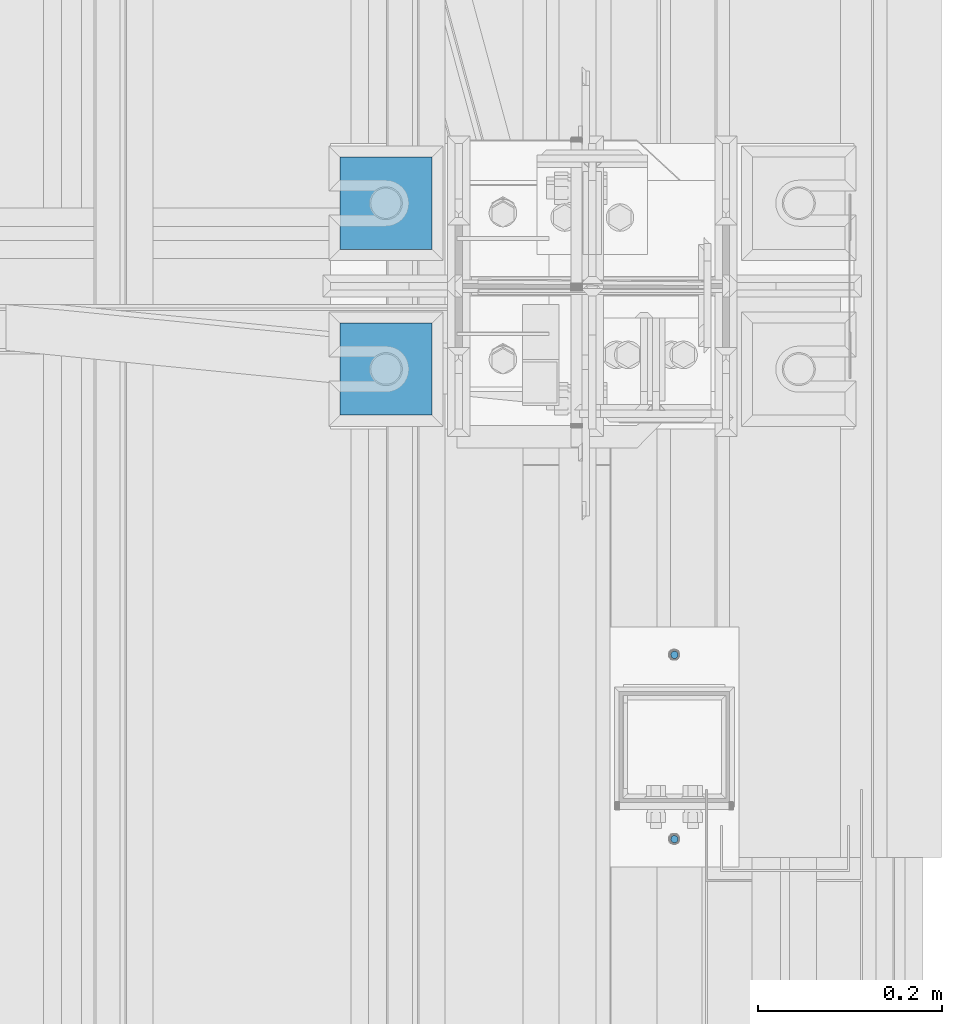
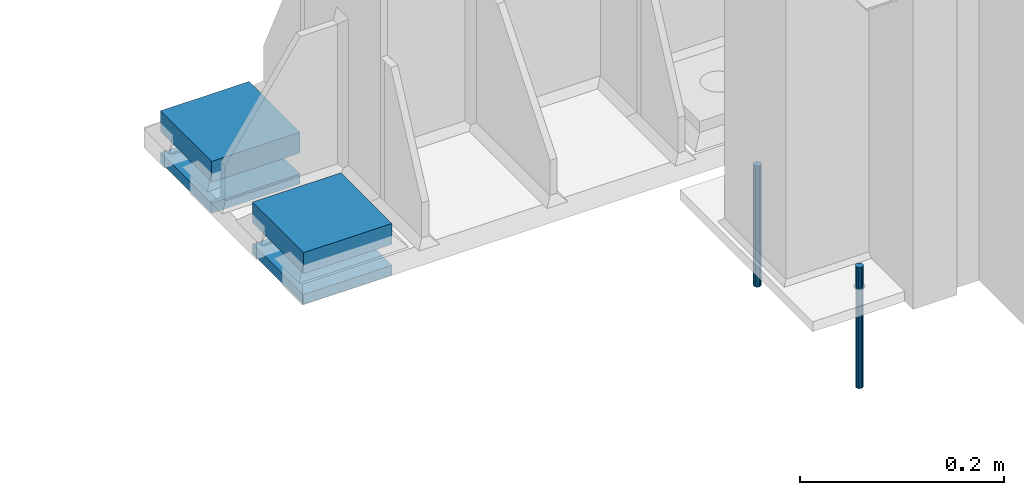
# One storey, part 101 of 709: 6 beams, 6 elements without a shape of their own.
"""IFC4 building model written with IfcOpenShell, lengths in millimetres."""

import ifcopenshell
import ifcopenshell.guid

model = None  # the IFC model being written
_history = None  # IfcOwnerHistory: only IFC2X3 demands one
_inside = {}  # id of a spatial element -> (the spatial element, [elements in it])
_under = {}  # id of a project, library or spatial element -> (it, [spatial elements below it])
_declared = {}  # id of a project -> (the project, [libraries it declares])
_typed = {}  # id of a type object -> (the type object, [elements of that type])
_made_of = {}  # id of a material, layer set ... -> (it, [elements and type objects made of it])


def new_model(schema):
    """Start an empty IFC model of exactly this schema.

    Asked for "IFC4X3", IfcOpenShell would pick the latest addendum, in which some entities
    have other attributes; the version numbers below select the first issue.
    IFC2X3 requires an IfcOwnerHistory on every rooted entity: one is made here for all.
    """
    global model, _history
    if schema == "IFC4X3":
        model = ifcopenshell.file(schema_version=(4, 3, 0, 0))
    else:
        model = ifcopenshell.file(schema=schema)
    _inside.clear()
    _under.clear()
    _declared.clear()
    _typed.clear()
    _made_of.clear()
    _history = None
    if model.schema == "IFC2X3":
        org = make("IfcOrganization", Name="unknown")
        user = make(
            "IfcPersonAndOrganization",
            ThePerson=make("IfcPerson", FamilyName="unknown"),
            TheOrganization=org,
        )
        app = make(
            "IfcApplication",
            ApplicationDeveloper=org,
            Version="unknown",
            ApplicationFullName="unknown",
            ApplicationIdentifier="unknown",
        )
        _history = make(
            "IfcOwnerHistory",
            OwningUser=user,
            OwningApplication=app,
            ChangeAction="ADDED",
            CreationDate=0,
        )
    return model


def make(cls, **values):
    """One entity of the class cls with the attributes given. An attribute that is None is left unset."""
    return model.create_entity(
        cls, **{name: value for name, value in values.items() if value is not None}
    )


def rooted(cls, **values):
    """An entity with a GlobalId (a new one), such as an element, a storey or a relation."""
    return make(cls, GlobalId=ifcopenshell.guid.new(), OwnerHistory=_history, **values)


def si_unit(unit_type, name, prefix=None):
    """IfcSIUnit, for example si_unit("LENGTHUNIT", "METRE", prefix="MILLI")."""
    return make("IfcSIUnit", UnitType=unit_type, Prefix=prefix, Name=name)


def assignment(units):
    """IfcUnitAssignment: the units of a project."""
    return None if units is None else make("IfcUnitAssignment", Units=units)


def point(xyz):
    """IfcCartesianPoint."""
    return None if xyz is None else make("IfcCartesianPoint", Coordinates=xyz)


def direction(xyz):
    """IfcDirection."""
    return None if xyz is None else make("IfcDirection", DirectionRatios=xyz)


def frame(location, z_axis=None, x_axis=None):
    """IfcAxis2Placement3D, a coordinate frame: its origin and axes. An axis left out is left unset."""
    return make(
        "IfcAxis2Placement3D",
        Location=point(location),
        Axis=direction(z_axis),
        RefDirection=direction(x_axis),
    )


def origin_with_axes():
    """The frame at (0, 0, 0) with the z axis (0, 0, 1) and the x axis (1, 0, 0) written out."""
    return frame((0.0, 0.0, 0.0), z_axis=(0.0, 0.0, 1.0), x_axis=(1.0, 0.0, 0.0))


def place(relative_to, where):
    """IfcLocalPlacement: puts the frame where relative to a parent placement (None: the world)."""
    return make(
        "IfcLocalPlacement", PlacementRelTo=relative_to, RelativePlacement=where
    )


def context(
    kind, dimensions, precision=None, world=None, true_north=None, identifier=None
):
    """IfcGeometricRepresentationContext, for example the 3D "Model" context."""
    return make(
        "IfcGeometricRepresentationContext",
        ContextIdentifier=identifier,
        ContextType=kind,
        CoordinateSpaceDimension=dimensions,
        Precision=precision,
        WorldCoordinateSystem=world,
        TrueNorth=true_north,
    )


def subcontext(parent, identifier, kind, view, scale=None):
    """IfcGeometricRepresentationSubContext, for example "Body" below "Model"."""
    return make(
        "IfcGeometricRepresentationSubContext",
        ContextIdentifier=identifier,
        ContextType=kind,
        ParentContext=parent,
        TargetScale=scale,
        TargetView=view,
    )


def project(units=None, contexts=None):
    """IfcProject with its units and contexts."""
    return rooted(
        "IfcProject",
        Name="project",
        RepresentationContexts=contexts,
        UnitsInContext=assignment(units),
    )


def spatial(cls, under=None, at=None, **own):
    """A site, building, storey or space (cls), placed at a placement, below another one or the project."""
    s = rooted(cls, ObjectPlacement=at, **own)
    if under is not None:
        _under.setdefault(under.id(), (under, []))[1].append(s)
    return s


def point_list(points):
    """IfcCartesianPointList2D or 3D."""
    cls = (
        "IfcCartesianPointList2D" if len(points[0]) == 2 else "IfcCartesianPointList3D"
    )
    return make(cls, CoordList=points)


def line(*indices):
    """IfcLineIndex: a straight run through numbered points of an indexed curve."""
    return model.create_entity("IfcLineIndex", indices)


def indexed_curve(points, segments=None, self_intersect=None):
    """IfcIndexedPolyCurve: lines and arcs through numbered points (the first is 1)."""
    return make(
        "IfcIndexedPolyCurve",
        Points=point_list(points),
        Segments=segments,
        SelfIntersect=self_intersect,
    )


def outline(outer, holes=None, kind="AREA"):
    """IfcArbitraryClosedProfileDef: a profile drawn as a closed curve; with holes, ...WithVoids."""
    if holes is None:
        return make("IfcArbitraryClosedProfileDef", ProfileType=kind, OuterCurve=outer)
    return make(
        "IfcArbitraryProfileDefWithVoids",
        ProfileType=kind,
        OuterCurve=outer,
        InnerCurves=holes,
    )


def extrude(swept, where, along, depth):
    """IfcExtrudedAreaSolid: the profile swept, set in the frame where, extruded along a direction by depth."""
    return make(
        "IfcExtrudedAreaSolid",
        SweptArea=swept,
        Position=where,
        ExtrudedDirection=direction(along),
        Depth=depth,
    )


def shape(context_of_items, identifier, shape_type, items):
    """IfcShapeRepresentation: the items that make up one representation, for example the "Body"."""
    return make(
        "IfcShapeRepresentation",
        ContextOfItems=context_of_items,
        RepresentationIdentifier=identifier,
        RepresentationType=shape_type,
        Items=items,
    )


def material(Name=None, Category=None):
    """IfcMaterial."""
    return make("IfcMaterial", Name=Name, Category=Category)


def made_of(thing, what):
    """Note that an element or type object is made of a material, layer set ...; save() writes the relation."""
    if what is not None:
        _made_of.setdefault(what.id(), (what, []))[1].append(thing)
    return thing


def element(
    cls,
    number,
    at=None,
    inside=None,
    cuts=None,
    type_object=None,
    material=None,
    context=None,
    identifier="Body",
    shape_type=None,
    held_by="IfcProductDefinitionShape",
    body=None,
    shapes=None,
    **own,
):
    """One element of the class cls, such as IfcWall. Its Tag is "e" and its number.

    at: its placement. inside: the storey or other place that contains it. cuts: it is an
    opening in that element (IfcRelVoidsElement). A single representation is given by context,
    identifier, shape_type and body (its items); several are given by shapes. held_by: the class
    of the entity that holds the representations. save() writes the other relations.
    """
    e = rooted(cls, Tag="e%d" % number, ObjectPlacement=at, **own)
    if body is not None:
        shapes = [shape(context, identifier, shape_type, body)]
    if shapes is not None:
        e.Representation = make(held_by, Representations=shapes)
    if inside is not None:
        _inside.setdefault(inside.id(), (inside, []))[1].append(e)
    if cuts is not None:
        rooted(
            "IfcRelVoidsElement", RelatingBuildingElement=cuts, RelatedOpeningElement=e
        )
    if type_object is not None:
        _typed.setdefault(type_object.id(), (type_object, []))[1].append(e)
    return made_of(e, material)


def aggregate(whole, parts):
    """IfcRelAggregates: a whole, such as a stair, and the parts it consists of."""
    return rooted("IfcRelAggregates", RelatingObject=whole, RelatedObjects=parts)


def save(model, path):
    """Write the relations noted so far, then the file.

    IfcRelAggregates (storeys below a building ...), IfcRelContainedInSpatialStructure (elements
    in a storey), IfcRelDefinesByType, IfcRelAssociatesMaterial and IfcRelDeclares: one each for
    every whole, place, type object, material and project.
    """
    for whole, parts in _under.values():
        aggregate(whole, parts)
    for where, things in _inside.values():
        rooted(
            "IfcRelContainedInSpatialStructure",
            RelatedElements=things,
            RelatingStructure=where,
        )
    for kind, things in _typed.values():
        rooted("IfcRelDefinesByType", RelatedObjects=things, RelatingType=kind)
    for what, things in _made_of.values():
        rooted("IfcRelAssociatesMaterial", RelatedObjects=things, RelatingMaterial=what)
    for by, libraries in _declared.values():
        rooted("IfcRelDeclares", RelatingContext=by, RelatedDefinitions=libraries)
    model.write(path)


model = new_model("IFC4")

# Units and contexts
model_context = context("Model", 3, precision=0.2, world=origin_with_axes(), true_north=direction((0.0, 1.0)))
body_context = subcontext(model_context, "Body", "Model", "MODEL_VIEW")
ifc_project = project(units=[si_unit("LENGTHUNIT", "METRE", prefix="MILLI"), si_unit("AREAUNIT", "SQUARE_METRE"), si_unit("VOLUMEUNIT", "CUBIC_METRE"), si_unit("MASSUNIT", "GRAM", prefix="KILO"), si_unit("TIMEUNIT", "SECOND"), si_unit("PLANEANGLEUNIT", "RADIAN"), si_unit("SOLIDANGLEUNIT", "STERADIAN"), si_unit("THERMODYNAMICTEMPERATUREUNIT", "DEGREE_CELSIUS"), si_unit("LUMINOUSINTENSITYUNIT", "LUMEN")], contexts=[model_context])

# Site, building, storey
site_placement = place(None, origin_with_axes())
site = spatial("IfcSite", under=ifc_project, at=site_placement, CompositionType="ELEMENT")
building_placement = place(site_placement, origin_with_axes())
building = spatial("IfcBuilding", under=site, at=building_placement, Name="Undefined", CompositionType="ELEMENT")
storey_placement = place(building_placement, origin_with_axes())
storey = spatial("IfcBuildingStorey", under=building, at=storey_placement, Name="Undefined", CompositionType="ELEMENT", Elevation=0.0)

# Assembly, beam
assembly_1_placement = place(storey_placement, frame((49627.0, 5460.0, -162.5), z_axis=(0.0, 0.0, -1.0), x_axis=(0.0, -1.0, 0.0)))
assembly_1 = element("IfcElementAssembly", 1, at=assembly_1_placement, inside=storey)
ifc_material_1 = material(Name="C355-6", Category="STEEL")
beam_1_placement = place(assembly_1_placement, origin_with_axes())
beam_1 = element("IfcBeam", 2, at=beam_1_placement, material=ifc_material_1, ObjectType="421", context=body_context, shape_type="SolidModel", body=[
    extrude(outline(indexed_curve([(-12.5, -50.0), (12.5, -50.0), (12.5, 50.0), (-12.5, 50.0)], segments=[line(1, 2, 3, 4, 1)])), frame((0.0, 0.0, 0.0), z_axis=(-1.0, 0.0, 0.0), x_axis=(0.0, 0.0, 1.0)), (0.0, 0.0, -1.0), 100.0),
])
aggregate(assembly_1, [beam_1])

assembly_2_placement = place(storey_placement, frame((49627.0, 5460.0, -206.0), z_axis=(0.0, 0.0, -1.0), x_axis=(0.0, -1.0, 0.0)))
assembly_2 = element("IfcElementAssembly", 3, at=assembly_2_placement, inside=storey)
beam_2_placement = place(assembly_2_placement, origin_with_axes())
beam_2 = element("IfcBeam", 4, at=beam_2_placement, material=ifc_material_1, ObjectType="422", context=body_context, shape_type="SolidModel", body=[
    extrude(outline(indexed_curve([(-6.0, -50.0), (6.0, -50.0), (6.0, 50.0), (-6.0, 50.0)], segments=[line(1, 2, 3, 4, 1)])), frame((0.0, 0.0, 0.0), z_axis=(-1.0, 0.0, 0.0), x_axis=(0.0, 0.0, 1.0)), (0.0, 0.0, -1.0), 100.0),
])
aggregate(assembly_2, [beam_2])

assembly_3_placement = place(storey_placement, frame((49627.0, 5640.0, -162.5), z_axis=(0.0, 0.0, -1.0), x_axis=(0.0, -1.0, 0.0)))
assembly_3 = element("IfcElementAssembly", 5, at=assembly_3_placement, inside=storey)
beam_3_placement = place(assembly_3_placement, origin_with_axes())
beam_3 = element("IfcBeam", 6, at=beam_3_placement, material=ifc_material_1, ObjectType="421", context=body_context, shape_type="SolidModel", body=[
    extrude(outline(indexed_curve([(-12.5, -50.0), (12.5, -50.0), (12.5, 50.0), (-12.5, 50.0)], segments=[line(1, 2, 3, 4, 1)])), frame((0.0, 0.0, 0.0), z_axis=(-1.0, 0.0, 0.0), x_axis=(0.0, 0.0, 1.0)), (0.0, 0.0, -1.0), 100.0),
])
aggregate(assembly_3, [beam_3])

assembly_4_placement = place(storey_placement, frame((49627.0, 5640.0, -206.0), z_axis=(0.0, 0.0, -1.0), x_axis=(0.0, -1.0, 0.0)))
assembly_4 = element("IfcElementAssembly", 7, at=assembly_4_placement, inside=storey)
beam_4_placement = place(assembly_4_placement, origin_with_axes())
beam_4 = element("IfcBeam", 8, at=beam_4_placement, material=ifc_material_1, ObjectType="422", context=body_context, shape_type="SolidModel", body=[
    extrude(outline(indexed_curve([(-6.0, -50.0), (6.0, -50.0), (6.0, 50.0), (-6.0, 50.0)], segments=[line(1, 2, 3, 4, 1)])), frame((0.0, 0.0, 0.0), z_axis=(-1.0, 0.0, 0.0), x_axis=(0.0, 0.0, 1.0)), (0.0, 0.0, -1.0), 100.0),
])
aggregate(assembly_4, [beam_4])

assembly_5_placement = place(storey_placement, frame((49940.0, 5100.0, -13.0), z_axis=(0.0, 1.0, 0.0), x_axis=(0.0, 0.0, -1.0)))
assembly_5 = element("IfcElementAssembly", 9, at=assembly_5_placement, inside=storey)
ifc_material_2 = material(Name="Steel_Undefined", Category="STEEL")
beam_5_placement = place(assembly_5_placement, origin_with_axes())
beam_5 = element("IfcBeam", 10, at=beam_5_placement, material=ifc_material_2, context=body_context, shape_type="SolidModel", body=[
    extrude(outline(indexed_curve([(4.0, 0.0), (3.69552, 1.53073), (2.82843, 2.82843), (1.53073, 3.69552), (0.0, 4.0), (-1.53073, 3.69552), (-2.82843, 2.82843), (-3.69552, 1.53073), (-4.0, 0.0), (-3.69552, -1.53073), (-2.82843, -2.82843), (-1.53073, -3.69552), (0.0, -4.0), (1.53073, -3.69552), (2.82843, -2.82843), (3.69552, -1.53073)], segments=[line(1, 2, 3, 4, 5, 6, 7, 8, 9, 10, 11, 12, 13, 14, 15, 16, 1)])), frame((0.0, 0.0, 0.0), z_axis=(-1.0, 0.0, 0.0), x_axis=(0.0, 0.0, 1.0)), (0.0, 0.0, -1.0), 145.0),
])
aggregate(assembly_5, [beam_5])

assembly_6_placement = place(storey_placement, frame((49940.0, 4900.0, -13.0), z_axis=(0.0, 1.0, 0.0), x_axis=(0.0, 0.0, -1.0)))
assembly_6 = element("IfcElementAssembly", 11, at=assembly_6_placement, inside=storey)
beam_6_placement = place(assembly_6_placement, origin_with_axes())
beam_6 = element("IfcBeam", 12, at=beam_6_placement, material=ifc_material_2, context=body_context, shape_type="SolidModel", body=[
    extrude(outline(indexed_curve([(4.0, 0.0), (3.69552, 1.53073), (2.82843, 2.82843), (1.53073, 3.69552), (0.0, 4.0), (-1.53073, 3.69552), (-2.82843, 2.82843), (-3.69552, 1.53073), (-4.0, 0.0), (-3.69552, -1.53073), (-2.82843, -2.82843), (-1.53073, -3.69552), (0.0, -4.0), (1.53073, -3.69552), (2.82843, -2.82843), (3.69552, -1.53073)], segments=[line(1, 2, 3, 4, 5, 6, 7, 8, 9, 10, 11, 12, 13, 14, 15, 16, 1)])), frame((0.0, 0.0, 0.0), z_axis=(-1.0, 0.0, 0.0), x_axis=(0.0, 0.0, 1.0)), (0.0, 0.0, -1.0), 145.0),
])
aggregate(assembly_6, [beam_6])

save(model, "model.ifc")
